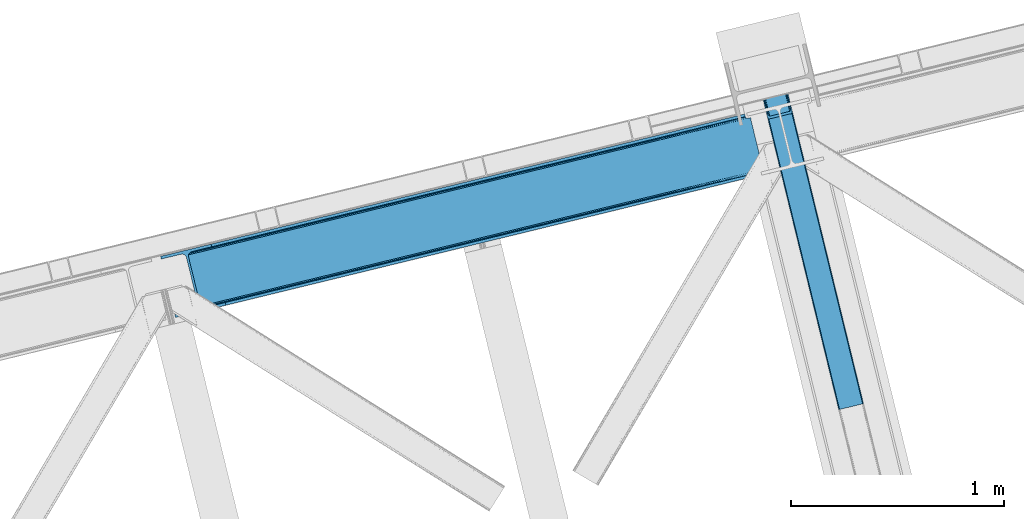
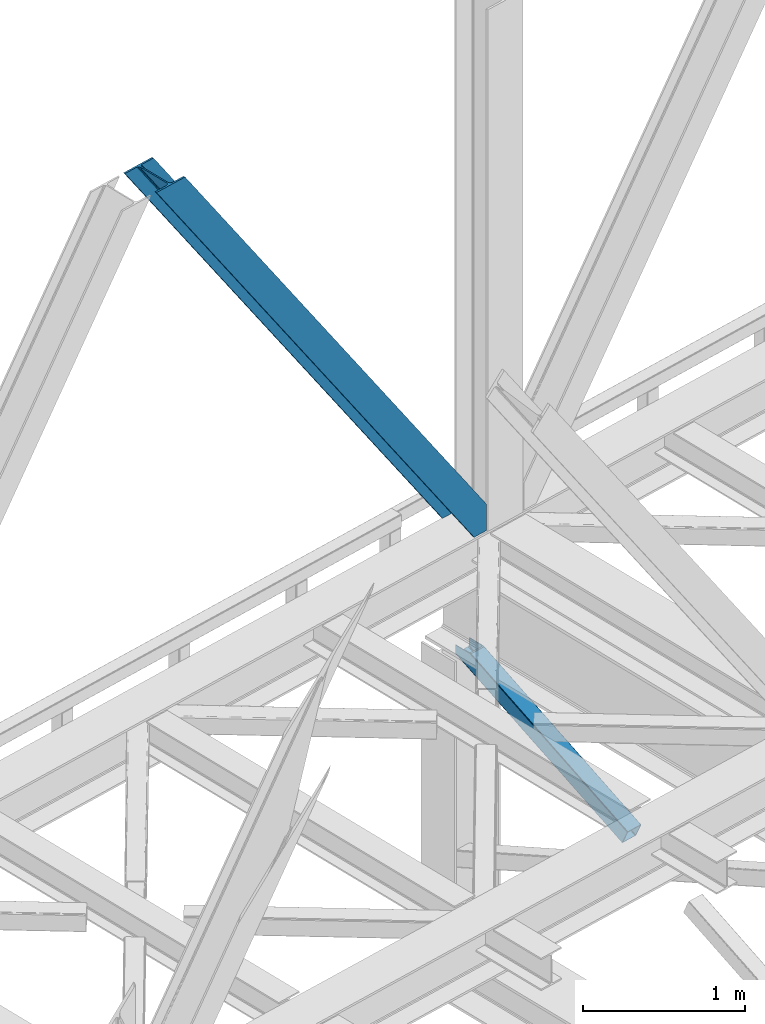
# One storey, part 31 of 92: 2 members.
"""IFC4 building model written with IfcOpenShell, lengths in millimetres."""

from ifc_helpers import new_model, entity, si_unit, converted_unit, derived_unit, direction, frame, origin, place, context, subcontext, project, spatial, triangles, type_object, element, save


model = new_model("IFC4")

# Units and contexts
model_context = context("Model", 3, precision=0.01, world=origin(), true_north=direction((6.12303176911189e-17, 1.0)))
plan_context = context("Plan", 3, precision=0.01, world=origin(), true_north=direction((6.12303176911189e-17, 1.0)))
body_context = subcontext(model_context, "Body", "Model", "MODEL_VIEW")
ifc_project = project(units=[si_unit("LENGTHUNIT", "METRE", prefix="MILLI"), si_unit("AREAUNIT", "SQUARE_METRE"), si_unit("VOLUMEUNIT", "CUBIC_METRE"), converted_unit("PLANEANGLEUNIT", "DEGREE", entity("IfcRatioMeasure", 0.0174532925199433), si_unit("PLANEANGLEUNIT", "RADIAN"), dimensions=[0, 0, 0, 0, 0, 0, 0]), si_unit("MASSUNIT", "GRAM", prefix="KILO"), derived_unit("MASSDENSITYUNIT", [(si_unit("MASSUNIT", "GRAM", prefix="KILO"), 1), (si_unit("LENGTHUNIT", "METRE"), -3)]), derived_unit("MOMENTOFINERTIAUNIT", [(si_unit("LENGTHUNIT", "METRE"), 4)]), si_unit("TIMEUNIT", "SECOND"), si_unit("FREQUENCYUNIT", "HERTZ"), si_unit("THERMODYNAMICTEMPERATUREUNIT", "DEGREE_CELSIUS"), derived_unit("THERMALTRANSMITTANCEUNIT", [(si_unit("MASSUNIT", "GRAM", prefix="KILO"), 1), (si_unit("THERMODYNAMICTEMPERATUREUNIT", "KELVIN"), -1), (si_unit("TIMEUNIT", "SECOND"), -3)]), derived_unit("VOLUMETRICFLOWRATEUNIT", [(si_unit("LENGTHUNIT", "METRE"), 3), (si_unit("TIMEUNIT", "SECOND"), -1)]), derived_unit("MASSFLOWRATEUNIT", [(si_unit("MASSUNIT", "GRAM", prefix="KILO"), 1), (si_unit("TIMEUNIT", "SECOND"), -1)]), derived_unit("ROTATIONALFREQUENCYUNIT", [(si_unit("TIMEUNIT", "SECOND"), -1)]), si_unit("ELECTRICCURRENTUNIT", "AMPERE"), si_unit("ELECTRICVOLTAGEUNIT", "VOLT"), si_unit("POWERUNIT", "WATT"), si_unit("FORCEUNIT", "NEWTON", prefix="KILO"), si_unit("ILLUMINANCEUNIT", "LUX"), si_unit("LUMINOUSFLUXUNIT", "LUMEN"), si_unit("LUMINOUSINTENSITYUNIT", "CANDELA"), derived_unit("USERDEFINED", [(si_unit("MASSUNIT", "GRAM", prefix="KILO"), -1), (si_unit("LENGTHUNIT", "METRE"), -2), (si_unit("TIMEUNIT", "SECOND"), 3), (si_unit("LUMINOUSFLUXUNIT", "LUMEN"), 1)]), derived_unit("LINEARVELOCITYUNIT", [(si_unit("LENGTHUNIT", "METRE"), 1), (si_unit("TIMEUNIT", "SECOND"), -1)]), si_unit("PRESSUREUNIT", "PASCAL"), derived_unit("USERDEFINED", [(si_unit("LENGTHUNIT", "METRE"), -2), (si_unit("MASSUNIT", "GRAM", prefix="KILO"), 1), (si_unit("TIMEUNIT", "SECOND"), -2)]), derived_unit("LINEARFORCEUNIT", [(si_unit("MASSUNIT", "GRAM", prefix="KILO"), 1), (si_unit("LENGTHUNIT", "METRE"), 1), (si_unit("TIMEUNIT", "SECOND"), -2), (si_unit("LENGTHUNIT", "METRE"), -1)]), derived_unit("PLANARFORCEUNIT", [(si_unit("MASSUNIT", "GRAM", prefix="KILO"), 1), (si_unit("LENGTHUNIT", "METRE"), 1), (si_unit("TIMEUNIT", "SECOND"), -2), (si_unit("LENGTHUNIT", "METRE"), -2)])], contexts=[model_context, plan_context])

# Site, building, storey
site_placement = place(None, origin())
site = spatial("IfcSite", under=ifc_project, at=site_placement, CompositionType="ELEMENT")
building_placement = place(site_placement, origin())
building = spatial("IfcBuilding", under=site, at=building_placement, CompositionType="ELEMENT")
storey_placement = place(building_placement, frame((0.0, 0.0, 15900.0)))
storey = spatial("IfcBuildingStorey", under=building, at=storey_placement, Name="05", CompositionType="ELEMENT", Elevation=15900.0)

# Members
member_type_1 = type_object("IfcMemberType", PredefinedType="BRACE")
member_1_placement = place(storey_placement, frame((-58108.15, 6493.08, 3695.0)))
element("IfcMember", 1, at=member_1_placement, inside=storey, type_object=member_type_1, ObjectType="Steel Vertical Brace", PredefinedType="BRACE", context=body_context, shape_type="Tessellation", body=[
    triangles([(2824.16715087891, 696.208666992187, 0.781347656247817), (2824.83687744141, 695.227331542969, 1.0697021484375), (2823.33929443359, 694.862237548828, 0.0), (2821.44638671875, 702.634437561035, 0.0), (2812.37717285156, 692.190307617188, 19.5569458007813), (2812.37717285156, 692.190307617188, 0.0), (2386.756640625, 583.574263000489, 658.75048828125), (2392.34234619141, 580.919192504883, 662.07819213867), (2803.98698730469, 681.261904907226, 51.2480346679658), (2804.11256103516, 683.186206054687, 44.4996093749978), (2382.25924072266, 588.488497924805, 656.525042724606), (2808.48438720703, 690.37995300293, 26.4030395507798), (2805.01483154297, 685.664543151855, 38.2720825195283), (2805.58223876954, 687.217936706543, 34.3676696777329), (630.515002441411, 150.046073913574, 3288.98063964843), (624.692102050787, 150.036772155762, 3285.05529785156), (211.331286621098, 47.865682983399, 3911.00081176758), (202.862036132814, 47.2110717773439, 3911.00081176758), (619.106396484378, 152.691261291504, 3281.72759399414), (195.034606933594, 49.3190826416021, 3911.00081176758), (614.608996582036, 157.60549621582, 3279.50447387695), (189.03962402344, 53.8676422119142, 3911.00081176758), (611.88358154297, 164.031266784668, 3278.7231262207), (185.784008789065, 60.1649322509766, 3911.00081176758), (2804.10325927735, 679.880593872071, 63.6403015136711), (2398.16524658204, 580.929075622559, 666.003533935545), (1950.42978515625, 473.1990234375, 1317.82188720703), (1956.25268554688, 473.208325195313, 1321.74955444336), (1508.5172241211, 365.478273010254, 1973.56790771484), (1514.34012451172, 365.487574768066, 1977.49324951172), (1072.42756347657, 257.766824340821, 2633.23694458008), (1066.60466308594, 257.757522583008, 2629.3116027832), (1944.84407958985, 475.853512573242, 1314.49418334961), (1502.93151855469, 368.132762145996, 1970.23787841797), (1061.01895751953, 260.41201171875, 2625.98389892578), (1940.3466796875, 480.767747497559, 1312.27106323242), (1498.43411865235, 373.046997070313, 1968.01475830078), (1056.52155761719, 265.326246643067, 2623.75845336914), (2379.5338256836, 594.91368713379, 655.74602050781), (1937.62126464844, 487.192936706543, 1311.48971557617), (1495.70870361329, 379.47276763916, 1967.23341064453), (1053.79614257813, 271.752017211914, 2622.97710571289), (2766.2637084961, 929.006085205078, 0.0), (2324.35114746094, 821.285334777832, 655.74602050781), (1882.43858642579, 713.564584350586, 1311.48971557617), (1440.52602539063, 605.844415283203, 1967.23341064453), (998.613464355469, 498.123664855957, 2622.97710571289), (556.705554199223, 390.402914428711, 3278.7231262207), (130.605981445318, 286.53657989502, 3911.00081176758), (303.26520996094, 70.2747802734375, 3911.00081176758), (2804.10325927735, 679.880593872071, 200.055230712889), (2807.13563232422, 667.239505004883, 200.120343017577), (2804.2939453125, 678.898095703125, 200.120343017577), (306.344091796876, 57.6441558837896, 3911.00081176758), (2807.13563232422, 667.239505004883, 0.0), (2804.2939453125, 678.898095703125, 0.0), (2803.9962890625, 682.092668151856, 0.0), (2804.11256103516, 683.186206054687, 2.42078247070094), (2804.71717529297, 685.456997680664, 5.12991943359157), (2805.58223876954, 687.217936706543, 5.67639770507594), (2807.01470947266, 689.087008666992, 4.89505004882813), (2808.48438720703, 690.37995300293, 3.35328369140552), (2811.03771972656, 691.772309875489, 0.0), (2705.51857910157, 642.469505310059, 0.0), (69.8608520507842, 0.0, 3911.00081176758), (2794.37362060547, 677.509226989746, 0.0), (2801.99641113282, 681.140400695801, 0.0), (2702.44434814453, 655.099548339844, 0.0), (66.7819702148481, 12.6300430297852, 3911.00081176758), (1480.00268554688, 357.117155456544, 1950.37164916992), (1034.28570556641, 248.469717407227, 2611.75686035156), (588.573376464847, 139.822279357911, 3273.1420715332), (158.71589355469, 35.0397216796873, 3911.00081176758), (1925.71501464844, 465.76459350586, 1288.98643798828), (2371.42734375, 574.412031555176, 627.598901367186), (2376.60377197266, 577.083380126954, 631.526568603513), (2380.34307861328, 582.010986328125, 634.854272460936), (2381.53370361328, 595.402029418946, 637.858740234373), (2811.39583740235, 700.184587097168, 0.0), (2811.09353027344, 693.083276367188, 0.0), (2382.07320556641, 588.443151855469, 637.077392578125), (598.679736328129, 160.81227722168, 3283.40191040039), (599.21923828125, 153.853399658204, 3282.62056274414), (175.738110351565, 57.7150817871097, 3911.00081176758), (175.747412109376, 50.6283050537113, 3911.00081176758), (597.484460449225, 147.420652770997, 3280.39744262695), (172.515051269533, 43.8298828124998, 3911.00081176758), (593.749804687504, 142.493627929688, 3277.06973876953), (166.5340209961, 38.3557983398441, 3911.00081176758), (1936.36087646485, 479.795713806153, 1298.46260375976), (1935.82137451172, 486.754591369629, 1299.24395141601), (1490.10904541016, 378.107153320313, 1960.63148803711), (1490.64389648438, 371.148275756836, 1959.85014038086), (1044.93156738282, 262.50083770752, 2621.2353515625), (1044.39206542969, 269.459715270997, 2622.01669921875), (1934.62609863281, 473.362966918946, 1296.23948364258), (1488.91376953125, 364.715528869629, 1957.62469482422), (1043.20144042969, 256.068090820313, 2619.01223144531), (1930.8914428711, 468.435942077637, 1292.91177978515), (1485.17446289063, 359.788504028321, 1954.2969909668), (1039.46213378906, 251.141065979004, 2615.68220214844), (2756.21315917969, 926.556234741211, 0.0), (2326.35567626954, 821.773677062988, 637.858740234373), (1434.9263671875, 604.478800964355, 1960.63148803711), (1880.64334716797, 713.126239013672, 1299.24395141601), (989.214038085942, 495.831362915039, 2622.01669921875), (543.501708984375, 387.183924865722, 3283.40191040039), (120.555432128909, 284.086729431153, 3911.00081176758), (2752.67849121094, 932.723881530762, 0.0), (2753.40867919922, 934.106936645509, 0.0), (2752.02736816407, 933.862184143067, 0.0), (2764.37080078125, 936.778866577149, 0.0), (2753.40867919922, 934.106936645509, 19.5569458007813), (2765.86838378906, 937.143960571289, 1.0697021484375), (2765.72420654297, 935.965544128419, 0.781347656247817), (2325.54642333985, 834.677540588379, 658.75048828125), (2749.12056884766, 933.923226928711, 26.4030395507798), (2745.08825683594, 935.395230102539, 34.3676696777329), (2323.81629638672, 828.244793701172, 656.525042724606), (2743.50695800781, 936.560275268555, 38.5441589355469), (556.166052246095, 397.361791992188, 3279.50447387695), (130.592028808598, 293.624519348145, 3911.00081176758), (557.896179199219, 403.794538879395, 3281.72759399414), (133.824389648442, 300.422360229492, 3911.00081176758), (561.635485839848, 408.721563720704, 3285.05529785156), (139.805419921875, 305.895863342285, 3911.00081176758), (566.811914062506, 411.393493652344, 3288.98063964843), (147.628198242193, 309.212521362305, 3911.00081176758), (2740.93037109375, 939.947277832031, 51.2480346679658), (2740.39552001953, 941.22801361084, 63.6403015136711), (2329.28572998047, 839.604565429688, 662.07819213867), (2334.45750732422, 842.276495361329, 666.003533935545), (2742.08843994141, 938.421208190918, 45.5251281738274), (1881.90373535157, 720.524043273926, 1312.27106323242), (1439.99117431641, 612.80329284668, 1968.01475830078), (998.07861328125, 505.082542419434, 2623.75845336914), (1883.63386230469, 726.956790161133, 1314.49418334961), (1441.72130126954, 619.236039733887, 1970.23787841797), (999.808740234381, 511.515289306641, 2625.98389892578), (1887.37316894531, 731.883815002441, 1317.82188720703), (1445.46060791016, 624.163064575196, 1973.56790771484), (1003.548046875, 516.442314147949, 2629.3116027832), (1892.54494628907, 734.555744934082, 1321.74955444336), (1450.63238525391, 626.834994506836, 1977.49324951172), (1008.72447509766, 519.11424407959, 2633.23694458008), (2740.39552001953, 941.22801361084, 200.055230712889), (239.557470703126, 331.622200012207, 3911.00081176758), (2749.12056884766, 933.923226928711, 3.35328369140552), (2745.08825683594, 935.395230102539, 5.67639770507594), (2747.22301025391, 934.392384338379, 4.89272460937354), (2743.50695800781, 936.560275268555, 5.12991943359157), (2740.11646728516, 942.189001464844, 0.0), (2741.92565917969, 938.297378540039, 2.42078247070094), (2740.11646728516, 942.189001464844, 200.120343017577), (2741.32104492188, 939.215927124023, 0.0), (2323.63026123047, 828.2000289917, 637.077392578125), (2319.13286132813, 833.113682556153, 634.854272460936), (2313.54715576172, 835.768171691895, 631.526568603513), (2307.7242553711, 835.758869934082, 627.598901367186), (2730.66588134766, 938.856646728516, 0.0), (2739.1072265625, 939.140931701661, 0.0), (524.865637207033, 401.16969909668, 3273.1420715332), (530.693188476565, 401.178419494629, 3277.06973876953), (103.477404785161, 297.041171264648, 3911.00081176758), (95.0081542968765, 296.387141418457, 3911.00081176758), (536.278894042975, 398.523930358887, 3280.39744262695), (111.309484863283, 294.933160400391, 3911.00081176758), (540.776293945317, 393.610276794434, 3282.62056274414), (117.304467773443, 290.384600830078, 3911.00081176758), (1867.83017578125, 727.120733642579, 1292.91177978515), (1862.00727539063, 727.112013244629, 1288.98643798828), (1416.29494628907, 618.463993835449, 1950.37164916992), (1422.11784667969, 618.473295593262, 1954.2969909668), (976.405517578125, 509.825857543946, 2615.68220214844), (970.582617187501, 509.817137145997, 2611.75686035156), (1873.41588134766, 724.466244506836, 1296.23948364258), (1427.70355224609, 615.81880645752, 1957.62469482422), (981.991223144534, 507.171368408203, 2619.01223144531), (1877.91793212891, 719.552590942383, 1298.46260375976), (1432.20095214844, 610.905152893067, 1959.85014038086), (986.488623046876, 502.25771484375, 2621.2353515625), (2737.27478027344, 953.847592163086, 200.120343017577), (236.47858886719, 344.252243041992, 3911.00081176758), (2737.27478027344, 953.847592163086, 0.0), (0.0, 286.608087158203, 3911.00081176758), (3.07888183594332, 273.977462768555, 3911.00081176758), (2635.65772705078, 929.077592468262, 0.0), (2638.73660888672, 916.446968078613, 0.0)], [[1, 2, 3], [3, 4, 1], [2, 5, 6], [6, 3, 2], [7, 8, 9], [9, 10, 7], [11, 12, 5], [5, 1, 11], [5, 2, 1], [11, 7, 13], [13, 14, 11], [14, 12, 11], [15, 16, 17], [18, 17, 16], [16, 19, 18], [20, 18, 19], [19, 21, 20], [22, 20, 21], [21, 23, 22], [24, 22, 23], [10, 13, 7], [25, 9, 8], [8, 26, 25], [26, 8, 27], [27, 28, 26], [28, 27, 29], [29, 30, 28], [30, 29, 31], [32, 31, 29], [31, 32, 16], [16, 15, 31], [8, 7, 27], [33, 27, 7], [27, 33, 34], [34, 29, 27], [29, 34, 35], [35, 32, 29], [32, 35, 16], [19, 16, 35], [7, 11, 36], [36, 33, 7], [33, 36, 34], [37, 34, 36], [34, 37, 35], [38, 35, 37], [35, 38, 21], [21, 19, 35], [1, 4, 11], [39, 11, 4], [11, 39, 40], [40, 36, 11], [36, 40, 41], [41, 37, 36], [37, 41, 42], [42, 38, 37], [38, 42, 21], [23, 21, 42], [4, 43, 44], [45, 39, 44], [41, 40, 45], [41, 45, 46], [44, 39, 4], [45, 40, 39], [42, 41, 46], [46, 47, 42], [47, 48, 23], [49, 24, 48], [47, 23, 42], [48, 24, 23], [50, 51, 30], [30, 31, 50], [31, 15, 50], [17, 50, 15], [28, 30, 51], [51, 25, 26], [26, 28, 51], [52, 53, 54], [53, 51, 50], [50, 54, 53], [52, 55, 53], [56, 53, 55], [56, 9, 25], [56, 57, 58], [58, 10, 56], [10, 9, 56], [59, 60, 14], [14, 13, 59], [10, 58, 59], [60, 61, 12], [12, 14, 60], [5, 62, 63], [63, 6, 5], [5, 12, 62], [61, 62, 12], [13, 10, 59], [25, 51, 53], [53, 56, 25], [54, 64, 52], [54, 65, 64], [64, 55, 52], [56, 66, 67], [55, 66, 56], [67, 57, 56], [64, 66, 55], [64, 68, 66], [68, 64, 69], [65, 69, 64], [69, 70, 68], [71, 69, 72], [69, 71, 70], [69, 73, 72], [74, 68, 70], [66, 68, 75], [74, 75, 68], [67, 76, 58], [76, 77, 59], [59, 58, 76], [76, 67, 66], [78, 79, 80], [81, 60, 59], [81, 80, 62], [62, 61, 81], [61, 60, 81], [80, 63, 62], [59, 77, 81], [80, 81, 78], [82, 83, 84], [85, 84, 83], [83, 86, 85], [87, 85, 86], [86, 88, 87], [89, 87, 88], [88, 72, 89], [73, 89, 72], [66, 75, 76], [58, 57, 67], [78, 81, 90], [90, 91, 78], [91, 90, 92], [93, 92, 90], [92, 93, 94], [94, 95, 92], [95, 94, 83], [83, 82, 95], [81, 77, 90], [96, 90, 77], [90, 96, 93], [97, 93, 96], [93, 97, 94], [98, 94, 97], [94, 98, 83], [86, 83, 98], [77, 76, 99], [99, 96, 77], [96, 99, 100], [100, 97, 96], [97, 100, 101], [101, 98, 97], [98, 101, 88], [88, 86, 98], [76, 75, 99], [74, 99, 75], [99, 74, 70], [70, 100, 99], [100, 70, 101], [71, 101, 70], [101, 71, 72], [72, 88, 101], [102, 79, 78], [91, 103, 78], [104, 105, 91], [104, 91, 92], [78, 103, 102], [91, 105, 103], [106, 104, 92], [92, 95, 106], [95, 82, 107], [84, 108, 82], [95, 107, 106], [82, 108, 107], [109, 102, 110], [6, 79, 80], [6, 80, 63], [110, 111, 109], [3, 79, 6], [79, 4, 102], [3, 4, 79], [43, 102, 4], [102, 112, 110], [112, 102, 43], [113, 114, 110], [112, 110, 114], [114, 115, 112], [43, 112, 115], [116, 117, 118], [119, 115, 113], [113, 116, 119], [113, 117, 116], [115, 114, 113], [118, 120, 116], [48, 121, 122], [122, 49, 48], [121, 123, 124], [124, 122, 121], [123, 125, 126], [126, 124, 123], [125, 127, 128], [128, 126, 125], [129, 130, 131], [132, 131, 130], [133, 116, 120], [116, 133, 129], [131, 116, 129], [43, 115, 119], [119, 44, 43], [44, 119, 45], [134, 45, 119], [45, 134, 46], [135, 46, 134], [46, 135, 136], [136, 47, 46], [47, 136, 121], [121, 48, 47], [119, 116, 134], [137, 134, 116], [134, 137, 138], [138, 135, 134], [135, 138, 139], [139, 136, 135], [136, 139, 121], [123, 121, 139], [116, 131, 140], [140, 137, 116], [137, 140, 138], [141, 138, 140], [138, 141, 139], [142, 139, 141], [139, 142, 125], [125, 123, 139], [131, 132, 140], [143, 140, 132], [140, 143, 141], [144, 141, 143], [141, 144, 145], [145, 142, 141], [142, 145, 127], [127, 125, 142], [144, 146, 147], [147, 127, 145], [127, 147, 128], [145, 144, 147], [146, 144, 143], [143, 132, 146], [130, 146, 132], [113, 110, 111], [148, 117, 113], [149, 118, 117], [117, 148, 150], [151, 133, 120], [118, 149, 151], [151, 120, 118], [152, 133, 153], [152, 129, 133], [146, 130, 154], [152, 154, 130], [130, 129, 152], [153, 155, 152], [151, 153, 133], [117, 150, 149], [111, 148, 113], [156, 150, 148], [156, 149, 150], [148, 109, 156], [148, 111, 109], [156, 157, 151], [151, 149, 156], [103, 156, 109], [158, 159, 160], [158, 153, 151], [158, 161, 153], [161, 155, 153], [151, 157, 158], [160, 161, 158], [162, 163, 164], [164, 165, 162], [163, 166, 167], [167, 164, 163], [166, 168, 169], [169, 167, 166], [168, 107, 108], [108, 169, 168], [109, 102, 103], [159, 158, 170], [170, 171, 159], [171, 170, 172], [173, 172, 170], [172, 173, 174], [174, 175, 172], [175, 174, 163], [163, 162, 175], [158, 157, 176], [176, 170, 158], [170, 176, 173], [177, 173, 176], [173, 177, 174], [178, 174, 177], [174, 178, 163], [166, 163, 178], [157, 156, 176], [179, 176, 156], [176, 179, 180], [180, 177, 176], [177, 180, 181], [181, 178, 177], [178, 181, 168], [168, 166, 178], [156, 103, 105], [105, 179, 156], [179, 105, 104], [104, 180, 179], [180, 104, 181], [106, 181, 104], [181, 106, 168], [107, 168, 106], [146, 154, 147], [154, 182, 183], [183, 147, 154], [154, 152, 184], [184, 182, 154], [108, 84, 49], [87, 89, 18], [73, 65, 54], [69, 65, 73], [89, 73, 17], [84, 85, 22], [85, 87, 20], [167, 126, 164], [185, 165, 183], [165, 164, 128], [185, 186, 165], [167, 169, 124], [169, 108, 122], [49, 84, 24], [17, 18, 89], [22, 85, 20], [18, 20, 87], [22, 24, 84], [54, 17, 73], [54, 50, 17], [128, 164, 126], [124, 169, 122], [49, 122, 108], [124, 126, 167], [128, 183, 165], [183, 128, 147], [152, 160, 184], [155, 161, 152], [152, 161, 160], [160, 187, 184], [187, 160, 188], [183, 187, 185], [187, 183, 182], [184, 187, 182], [172, 186, 188], [162, 186, 175], [162, 165, 186], [172, 175, 186], [188, 171, 172], [159, 171, 188], [188, 160, 159], [187, 188, 185], [186, 185, 188]]),
])
member_type_2 = type_object("IfcMemberType", PredefinedType="BRACE")
member_2_placement = place(storey_placement, frame((-55294.26, 6062.41, 1850.35)))
element("IfcMember", 2, at=member_2_placement, inside=storey, type_object=member_type_2, ObjectType="Steel Vertical Brace", PredefinedType="BRACE", context=body_context, shape_type="Tessellation", body=[
    triangles([(109.783996582031, 1519.24680175781, 671.707836914062), (462.204345703125, 73.4902816772465, 0.0), (359.21993408203, 48.3865814208984, 0.0), (6.79958496093604, 1494.14310150147, 671.707836914062), (464.859997558589, 73.9117675781254, 0.48601684570167), (467.213342285155, 73.843167114258, 1.86965332031104), (112.188500976561, 1519.8328125, 672.832186889649), (468.906262207027, 73.2943634033209, 3.93929443359229), (114.593005371091, 1520.41882324219, 673.956536865233), (469.687609863278, 72.3502349853516, 6.38100585937354), (115.588293457025, 1520.66183166504, 676.672650146484), (116.588232421869, 1520.90425872803, 679.387600708007), (353.099377441402, 43.9310394287113, 6.38100585937354), (0.0, 1492.48564453125, 679.387600708007), (0.99528808593459, 1492.72807159424, 676.672650146484), (353.355175781246, 45.1274780273443, 3.93929443359229), (1.99057617186918, 1492.97108001709, 673.956536865233), (354.610913085933, 46.3948425292974, 1.86965332031104), (4.39508056640625, 1493.55709075928, 672.832186889649), (356.671252441403, 47.5395401000978, 0.48601684570167), (144.939990234372, 1404.59100952148, 741.646591186523), (116.588232421869, 1520.90425872803, 741.646591186523), (480.012561035153, 29.9801467895513, 102.993713378906), (28.3517578124956, 1376.17181396484, 741.646591186523), (0.0, 1492.48564453125, 741.646591186523), (363.428979492186, 1.5615325927738, 102.993713378906), (476.445336914061, 26.3722274780275, 108.888702392578), (144.460949707027, 1388.29549255371, 741.646591186523), (142.168066406244, 1386.40316619873, 741.646591186523), (473.896655273435, 25.5246047973633, 109.37471923828), (478.505676269531, 27.5163436889652, 107.505065917969), (145.795751953119, 1392.41675262451, 741.646591186523), (479.75676269531, 28.7837081909183, 105.435424804688), (145.963183593747, 1398.13907775879, 741.646591186523), (39.1836547851563, 1361.29946594238, 741.646591186523), (370.912243652339, 0.420904541016171, 109.37471923828), (364.205676269528, 0.61682281494177, 105.435424804688), (30.4120971679658, 1369.97219238281, 741.646591186523), (365.90324707031, 0.0686004638673694, 107.505065917969), (33.1933227539048, 1364.96900939942, 741.646591186523), (368.256591796875, 0.0, 108.888702392578), (36.2722045898408, 1361.92326507568, 741.646591186523), (138.061340332031, 1403.03994140625, 741.646591186523), (137.200927734375, 1415.21419830322, 741.646591186523), (111.728063964838, 1519.72061004639, 741.646591186523), (138.228771972652, 1408.76226654053, 741.646591186523), (136.726538085932, 1398.91926269531, 741.646591186523), (134.433654785156, 1397.02635498047, 741.646591186523), (35.1745971679629, 1377.9600769043, 741.646591186523), (32.3933715820313, 1382.96384124756, 741.646591186523), (30.333032226561, 1389.16346282959, 741.646591186523), (4.85551757812209, 1493.66929321289, 741.646591186523), (38.2534790039063, 1374.91491394043, 741.646591186523), (41.1649291992144, 1374.29111480713, 741.646591186523), (474.668701171875, 30.7952133178715, 98.4370147705085), (474.412902832031, 29.5981933593757, 100.87872619629), (473.161816406246, 28.3308288574226, 102.948367309571), (471.101477050775, 27.1867126464849, 104.330841064453), (468.552795410156, 26.3390899658207, 104.816857910155), (375.284069824214, 3.60384979248101, 104.816857910155), (372.62841796875, 3.18236389160211, 104.330841064453), (370.275073242185, 3.25096435546948, 102.948367309571), (368.577502441403, 3.79976806640661, 100.87872619629), (367.800805664061, 4.743896484375, 98.4370147705085), (111.728063964838, 1519.72061004639, 684.873312377931), (465.315783691403, 69.1672897338867, 10.9377044677749), (4.85551757812209, 1493.66929321289, 684.873312377931), (358.443237304688, 43.1165542602539, 10.9377044677749), (462.84151611328, 70.6602218627932, 6.42635192871239), (464.539086914061, 70.1119995117188, 8.49599304199364), (460.488171386714, 70.7294036865242, 5.04387817382667), (457.83251953125, 70.3079177856453, 4.557861328125), (359.954772949219, 45.58035736084, 6.42635192871239), (362.015112304682, 46.7250549316414, 5.04387817382667), (358.703686523433, 44.3135742187505, 8.49599304199364), (364.563793945308, 47.572096252442, 4.557861328125), (11.6597534179673, 1495.32733154297, 677.193548583986), (9.2552490234375, 1494.74132080078, 678.31789855957), (6.85074462890043, 1494.15531005859, 679.443411254884), (104.928479003902, 1518.06257171631, 677.193548583986), (107.332983398432, 1518.6485824585, 678.31789855957), (109.737487792969, 1519.23459320068, 679.443411254884), (5.85545654296584, 1493.91230163574, 682.158361816408), (110.732775878903, 1519.47760162354, 682.158361816408)], [[1, 2, 3], [3, 4, 1], [5, 2, 1], [6, 5, 7], [8, 6, 9], [10, 8, 11], [11, 12, 10], [9, 11, 8], [7, 9, 6], [1, 7, 5], [13, 14, 15], [16, 15, 17], [18, 17, 19], [20, 19, 4], [4, 3, 20], [19, 20, 18], [17, 18, 16], [15, 16, 13], [12, 21, 10], [21, 12, 22], [23, 10, 21], [24, 14, 13], [24, 25, 14], [13, 26, 24], [27, 28, 29], [29, 30, 27], [31, 32, 28], [28, 27, 31], [33, 34, 32], [32, 31, 33], [23, 21, 34], [34, 33, 23], [30, 29, 35], [35, 36, 30], [37, 38, 26], [24, 26, 38], [39, 40, 37], [38, 37, 40], [41, 42, 39], [40, 39, 42], [36, 35, 41], [42, 41, 35], [43, 34, 21], [22, 44, 21], [44, 22, 45], [44, 46, 21], [46, 43, 21], [47, 34, 43], [32, 29, 28], [32, 34, 47], [32, 48, 29], [29, 48, 35], [47, 48, 32], [24, 38, 49], [49, 50, 24], [50, 51, 24], [51, 25, 24], [52, 25, 51], [38, 53, 49], [54, 40, 35], [54, 35, 48], [54, 53, 40], [35, 40, 42], [53, 38, 40], [44, 55, 46], [56, 46, 55], [46, 56, 43], [57, 43, 56], [43, 57, 47], [58, 47, 57], [47, 58, 48], [59, 48, 58], [48, 59, 54], [60, 54, 59], [54, 60, 61], [61, 53, 54], [53, 61, 62], [62, 49, 53], [49, 62, 63], [63, 50, 49], [50, 63, 64], [64, 51, 50], [44, 65, 66], [44, 45, 65], [66, 55, 44], [67, 51, 68], [51, 67, 52], [64, 68, 51], [55, 23, 56], [57, 33, 31], [31, 27, 57], [23, 55, 10], [23, 33, 57], [57, 56, 23], [59, 30, 36], [30, 58, 57], [59, 58, 30], [30, 57, 27], [6, 69, 5], [66, 10, 55], [69, 8, 10], [70, 10, 66], [8, 69, 6], [69, 2, 5], [10, 70, 69], [69, 71, 2], [2, 72, 3], [72, 2, 71], [62, 26, 63], [36, 60, 59], [61, 36, 62], [36, 61, 60], [62, 36, 41], [64, 63, 26], [41, 39, 62], [37, 62, 39], [64, 26, 13], [37, 26, 62], [73, 20, 3], [74, 73, 3], [75, 13, 73], [76, 3, 72], [3, 76, 74], [18, 20, 73], [13, 68, 64], [16, 73, 13], [68, 13, 75], [73, 16, 18], [77, 1, 4], [4, 19, 78], [19, 17, 15], [19, 79, 78], [4, 78, 77], [79, 19, 15], [80, 1, 77], [9, 7, 11], [7, 1, 81], [81, 82, 7], [7, 82, 11], [80, 81, 1], [11, 82, 12], [83, 14, 67], [15, 14, 79], [83, 79, 14], [25, 67, 14], [25, 52, 67], [12, 84, 65], [84, 12, 82], [65, 22, 12], [22, 65, 45], [72, 80, 76], [77, 76, 80], [66, 65, 84], [70, 84, 82], [69, 82, 81], [71, 81, 80], [80, 72, 71], [81, 71, 69], [82, 69, 70], [84, 70, 66], [74, 76, 77], [73, 74, 78], [75, 73, 79], [68, 75, 83], [83, 67, 68], [79, 83, 75], [78, 79, 73], [77, 78, 74]]),
])

save(model, "model.ifc")
